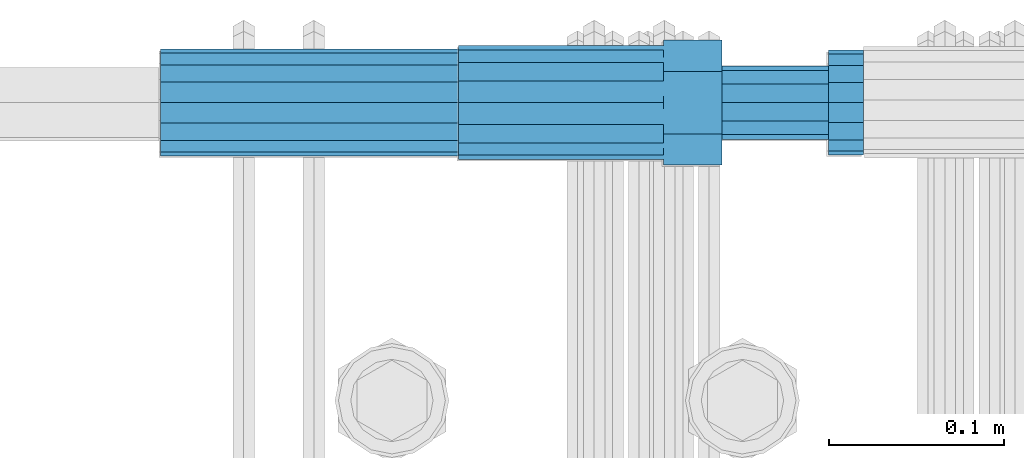
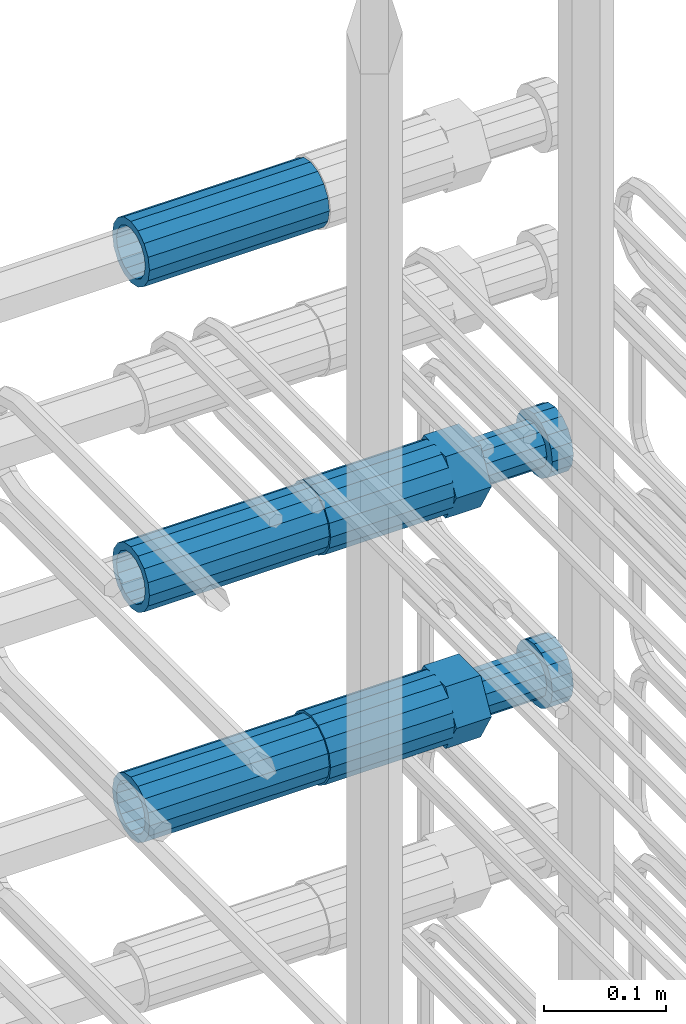
# One storey, part 55 of 177: 5 beams.
"""IFC2X3 building model written with IfcOpenShell, lengths in millimetres."""

from ifc_helpers import new_model, si_unit, frame, origin_with_axes, place, context, subcontext, project, spatial, faceted_brep, material, type_object, element, save


model = new_model("IFC2X3")

# Units and contexts
model_context_1 = context("Model", 3, precision=1e-05, world=origin_with_axes())
model_context_2 = context("Model", 3, precision=1e-05, world=origin_with_axes())
body_context = subcontext(model_context_2, "Body", "Model", "MODEL_VIEW")
ifc_project = project(units=[si_unit("LENGTHUNIT", "METRE", prefix="MILLI"), si_unit("AREAUNIT", "SQUARE_METRE"), si_unit("VOLUMEUNIT", "CUBIC_METRE"), si_unit("MASSUNIT", "GRAM", prefix="KILO"), si_unit("TIMEUNIT", "SECOND"), si_unit("PLANEANGLEUNIT", "RADIAN"), si_unit("SOLIDANGLEUNIT", "STERADIAN"), si_unit("THERMODYNAMICTEMPERATUREUNIT", "DEGREE_CELSIUS"), si_unit("LUMINOUSINTENSITYUNIT", "LUMEN")], contexts=[model_context_1])

# Site, building, storey
site_placement = place(None, origin_with_axes())
site = spatial("IfcSite", under=ifc_project, at=site_placement, CompositionType="ELEMENT")
building_placement = place(site_placement, origin_with_axes())
building = spatial("IfcBuilding", under=site, at=building_placement, Name="Undefined", CompositionType="ELEMENT")
storey_placement = place(building_placement, origin_with_axes())
storey = spatial("IfcBuildingStorey", under=building, at=storey_placement, Name="Undefined", CompositionType="ELEMENT", Elevation=0.0)

# Beams
ifc_material = material(Name="STEEL/S275")
beam_type_1 = type_object("IfcBeamType", PredefinedType="NOTDEFINED")
beam_1_placement = place(storey_placement, frame((2031449.01847313, 6206398.98588032, 21804.9868004311), z_axis=(0.0, 0.0, -1.0), x_axis=(1.0, 0.0, 0.0)))
element("IfcBeam", 1, at=beam_1_placement, inside=storey, type_object=beam_type_1, material=ifc_material, Name="AG40N", context=body_context, shape_type="Brep", body=[
    faceted_brep([(0.0, -23.5000000001164, -9.31322574615479e-10), (0.0, -21.7111690140155, 8.99306066054851), (170.0, -21.7111690140155, 8.99306066054851), (170.0, -23.5, 0.0), (0.0, -16.6170093578839, 16.6170093575493), (170.0, -16.6170093578839, 16.6170093575493), (0.0, -8.99306066057943, 21.7111690137535), (170.0, -8.99306066057943, 21.7111690137535), (0.0, 1.16415321826935e-10, 23.5), (170.0, 0.0, 23.5), (0.0, 8.99306066057943, 21.7111690137535), (170.0, 8.99306066057943, 21.7111690137535), (0.0, 16.6170093578839, 16.6170093575493), (170.0, 16.6170093578839, 16.6170093575493), (0.0, 21.7111690140155, 8.99306066054851), (170.0, 21.7111690140155, 8.99306066054851), (0.0, 23.5000000001164, -9.31322574615479e-10), (170.0, 23.5, 0.0), (0.0, 21.7111690140155, -8.99306066054851), (170.0, 21.7111690140155, -8.99306066054851), (0.0, 16.6170093578839, -16.6170093575493), (170.0, 16.6170093578839, -16.6170093575493), (0.0, 8.99306066057943, -21.7111690137535), (170.0, 8.99306066057943, -21.7111690137535), (0.0, 1.16415321826935e-10, -23.5000000009313), (170.0, 0.0, -23.5), (0.0, -8.99306066057943, -21.7111690137535), (170.0, -8.99306066057943, -21.7111690137535), (0.0, -16.6170093578839, -16.6170093575493), (170.0, -16.6170093578839, -16.6170093575493), (0.0, -21.7111690140155, -8.99306066054851), (170.0, -21.7111690140155, -8.99306066054851), (0.0, -30.5, 0.0), (0.0, -28.1783257415937, -11.6718446873128), (170.0, -28.1783257415937, -11.6718446873128), (170.0, -30.5, 0.0), (0.0, -21.5667568261888, -21.5667568258941), (170.0, -21.5667568261888, -21.5667568258941), (0.0, -11.6718446871346, -28.1783257415518), (170.0, -11.6718446871346, -28.1783257415518), (0.0, 0.0, -30.5), (170.0, 0.0, -30.5), (0.0, 11.6718446871346, -28.1783257415518), (170.0, 11.6718446871346, -28.1783257415518), (0.0, 21.5667568261888, -21.5667568258941), (170.0, 21.5667568261888, -21.5667568258941), (0.0, 28.1783257415937, -11.6718446873128), (170.0, 28.1783257415937, -11.6718446873128), (0.0, 30.5, 0.0), (170.0, 30.5, 0.0), (0.0, 28.1783257415937, 11.6718446873128), (170.0, 28.1783257415937, 11.6718446873128), (0.0, 21.5667568261888, 21.5667568258941), (170.0, 21.5667568261888, 21.5667568258941), (0.0, 11.6718446871346, 28.1783257415518), (170.0, 11.6718446871346, 28.1783257415518), (0.0, 0.0, 30.5), (170.0, 0.0, 30.5), (0.0, -11.6718446871346, 28.1783257415518), (170.0, -11.6718446871346, 28.1783257415518), (0.0, -21.5667568261888, 21.5667568258941), (170.0, -21.5667568261888, 21.5667568258941), (0.0, -28.1783257415937, 11.6718446873128), (170.0, -28.1783257415937, 11.6718446873128)], [[[0, 1, 2, 3]], [[1, 4, 5, 2]], [[4, 6, 7, 5]], [[6, 8, 9, 7]], [[8, 10, 11, 9]], [[10, 12, 13, 11]], [[12, 14, 15, 13]], [[14, 16, 17, 15]], [[16, 18, 19, 17]], [[18, 20, 21, 19]], [[20, 22, 23, 21]], [[22, 24, 25, 23]], [[24, 26, 27, 25]], [[26, 28, 29, 27]], [[28, 30, 31, 29]], [[30, 0, 3, 31]], [[32, 33, 34, 35]], [[33, 36, 37, 34]], [[36, 38, 39, 37]], [[38, 40, 41, 39]], [[40, 42, 43, 41]], [[42, 44, 45, 43]], [[44, 46, 47, 45]], [[46, 48, 49, 47]], [[48, 50, 51, 49]], [[50, 52, 53, 51]], [[52, 54, 55, 53]], [[54, 56, 57, 55]], [[56, 58, 59, 57]], [[58, 60, 61, 59]], [[60, 62, 63, 61]], [[62, 32, 35, 63]], [[37, 39, 41, 43, 45, 47, 49, 51, 53, 55, 57, 59, 61, 63, 35, 34], [5, 7, 9, 11, 13, 15, 17, 19, 21, 23, 25, 27, 29, 31, 3, 2]], [[62, 60, 58, 56, 54, 52, 50, 48, 46, 44, 42, 40, 38, 36, 33, 32], [30, 28, 26, 24, 22, 20, 18, 16, 14, 12, 10, 8, 6, 4, 1, 0]]]),
])
beam_2_placement = place(storey_placement, frame((2031449.01847313, 6206398.98588031, 22034.9868004306), z_axis=(0.0, 0.0, -1.0), x_axis=(1.0, 0.0, 0.0)))
element("IfcBeam", 2, at=beam_2_placement, inside=storey, type_object=beam_type_1, material=ifc_material, Name="AG40N", context=body_context, shape_type="Brep", body=[
    faceted_brep([(0.0, -23.5000000001164, -9.31322574615479e-10), (0.0, -21.7111690140155, 8.99306066054851), (170.0, -21.7111690140155, 8.99306066054851), (170.0, -23.5, 0.0), (0.0, -16.6170093578839, 16.6170093575493), (170.0, -16.6170093578839, 16.6170093575493), (0.0, -8.99306066057943, 21.7111690137535), (170.0, -8.99306066057943, 21.7111690137535), (0.0, 1.16415321826935e-10, 23.5), (170.0, 0.0, 23.5), (0.0, 8.99306066057943, 21.7111690137535), (170.0, 8.99306066057943, 21.7111690137535), (0.0, 16.6170093578839, 16.6170093575493), (170.0, 16.6170093578839, 16.6170093575493), (0.0, 21.7111690140155, 8.99306066054851), (170.0, 21.7111690140155, 8.99306066054851), (0.0, 23.5000000001164, -9.31322574615479e-10), (170.0, 23.5, 0.0), (0.0, 21.7111690140155, -8.99306066054851), (170.0, 21.7111690140155, -8.99306066054851), (0.0, 16.6170093578839, -16.6170093575493), (170.0, 16.6170093578839, -16.6170093575493), (0.0, 8.99306066057943, -21.7111690137535), (170.0, 8.99306066057943, -21.7111690137535), (0.0, 1.16415321826935e-10, -23.5000000009313), (170.0, 0.0, -23.5), (0.0, -8.99306066057943, -21.7111690137535), (170.0, -8.99306066057943, -21.7111690137535), (0.0, -16.6170093578839, -16.6170093575493), (170.0, -16.6170093578839, -16.6170093575493), (0.0, -21.7111690140155, -8.99306066054851), (170.0, -21.7111690140155, -8.99306066054851), (0.0, -30.5, 0.0), (0.0, -28.1783257415937, -11.6718446873128), (170.0, -28.1783257415937, -11.6718446873128), (170.0, -30.5, 0.0), (0.0, -21.5667568261888, -21.5667568258941), (170.0, -21.5667568261888, -21.5667568258941), (0.0, -11.6718446871346, -28.1783257415518), (170.0, -11.6718446871346, -28.1783257415518), (0.0, 0.0, -30.5), (170.0, 0.0, -30.5), (0.0, 11.6718446871346, -28.1783257415518), (170.0, 11.6718446871346, -28.1783257415518), (0.0, 21.5667568261888, -21.5667568258941), (170.0, 21.5667568261888, -21.5667568258941), (0.0, 28.1783257415937, -11.6718446873128), (170.0, 28.1783257415937, -11.6718446873128), (0.0, 30.5, 0.0), (170.0, 30.5, 0.0), (0.0, 28.1783257415937, 11.6718446873128), (170.0, 28.1783257415937, 11.6718446873128), (0.0, 21.5667568261888, 21.5667568258941), (170.0, 21.5667568261888, 21.5667568258941), (0.0, 11.6718446871346, 28.1783257415518), (170.0, 11.6718446871346, 28.1783257415518), (0.0, 0.0, 30.5), (170.0, 0.0, 30.5), (0.0, -11.6718446871346, 28.1783257415518), (170.0, -11.6718446871346, 28.1783257415518), (0.0, -21.5667568261888, 21.5667568258941), (170.0, -21.5667568261888, 21.5667568258941), (0.0, -28.1783257415937, 11.6718446873128), (170.0, -28.1783257415937, 11.6718446873128)], [[[0, 1, 2, 3]], [[1, 4, 5, 2]], [[4, 6, 7, 5]], [[6, 8, 9, 7]], [[8, 10, 11, 9]], [[10, 12, 13, 11]], [[12, 14, 15, 13]], [[14, 16, 17, 15]], [[16, 18, 19, 17]], [[18, 20, 21, 19]], [[20, 22, 23, 21]], [[22, 24, 25, 23]], [[24, 26, 27, 25]], [[26, 28, 29, 27]], [[28, 30, 31, 29]], [[30, 0, 3, 31]], [[32, 33, 34, 35]], [[33, 36, 37, 34]], [[36, 38, 39, 37]], [[38, 40, 41, 39]], [[40, 42, 43, 41]], [[42, 44, 45, 43]], [[44, 46, 47, 45]], [[46, 48, 49, 47]], [[48, 50, 51, 49]], [[50, 52, 53, 51]], [[52, 54, 55, 53]], [[54, 56, 57, 55]], [[56, 58, 59, 57]], [[58, 60, 61, 59]], [[60, 62, 63, 61]], [[62, 32, 35, 63]], [[37, 39, 41, 43, 45, 47, 49, 51, 53, 55, 57, 59, 61, 63, 35, 34], [5, 7, 9, 11, 13, 15, 17, 19, 21, 23, 25, 27, 29, 31, 3, 2]], [[62, 60, 58, 56, 54, 52, 50, 48, 46, 44, 42, 40, 38, 36, 33, 32], [30, 28, 26, 24, 22, 20, 18, 16, 14, 12, 10, 8, 6, 4, 1, 0]]]),
])
beam_3_placement = place(storey_placement, frame((2031449.01847313, 6206398.98588031, 22359.9868004311), z_axis=(0.0, 0.0, -1.0), x_axis=(1.0, 0.0, 0.0)))
element("IfcBeam", 3, at=beam_3_placement, inside=storey, type_object=beam_type_1, material=ifc_material, Name="AG40N", context=body_context, shape_type="Brep", body=[
    faceted_brep([(0.0, -23.5000000001164, -9.31322574615479e-10), (0.0, -21.7111690140155, 8.99306066054851), (170.0, -21.7111690140155, 8.99306066054851), (170.0, -23.5, 0.0), (0.0, -16.6170093578839, 16.6170093575493), (170.0, -16.6170093578839, 16.6170093575493), (0.0, -8.99306066057943, 21.7111690137535), (170.0, -8.99306066057943, 21.7111690137535), (0.0, 1.16415321826935e-10, 23.5), (170.0, 0.0, 23.5), (0.0, 8.99306066057943, 21.7111690137535), (170.0, 8.99306066057943, 21.7111690137535), (0.0, 16.6170093578839, 16.6170093575493), (170.0, 16.6170093578839, 16.6170093575493), (0.0, 21.7111690140155, 8.99306066054851), (170.0, 21.7111690140155, 8.99306066054851), (0.0, 23.5000000001164, -9.31322574615479e-10), (170.0, 23.5, 0.0), (0.0, 21.7111690140155, -8.99306066054851), (170.0, 21.7111690140155, -8.99306066054851), (0.0, 16.6170093578839, -16.6170093575493), (170.0, 16.6170093578839, -16.6170093575493), (0.0, 8.99306066057943, -21.7111690137535), (170.0, 8.99306066057943, -21.7111690137535), (0.0, 1.16415321826935e-10, -23.5000000009313), (170.0, 0.0, -23.5), (0.0, -8.99306066057943, -21.7111690137535), (170.0, -8.99306066057943, -21.7111690137535), (0.0, -16.6170093578839, -16.6170093575493), (170.0, -16.6170093578839, -16.6170093575493), (0.0, -21.7111690140155, -8.99306066054851), (170.0, -21.7111690140155, -8.99306066054851), (0.0, -30.5, 0.0), (0.0, -28.1783257415937, -11.6718446873128), (170.0, -28.1783257415937, -11.6718446873128), (170.0, -30.5, 0.0), (0.0, -21.5667568261888, -21.5667568258941), (170.0, -21.5667568261888, -21.5667568258941), (0.0, -11.6718446871346, -28.1783257415518), (170.0, -11.6718446871346, -28.1783257415518), (0.0, 0.0, -30.5), (170.0, 0.0, -30.5), (0.0, 11.6718446871346, -28.1783257415518), (170.0, 11.6718446871346, -28.1783257415518), (0.0, 21.5667568261888, -21.5667568258941), (170.0, 21.5667568261888, -21.5667568258941), (0.0, 28.1783257415937, -11.6718446873128), (170.0, 28.1783257415937, -11.6718446873128), (0.0, 30.5, 0.0), (170.0, 30.5, 0.0), (0.0, 28.1783257415937, 11.6718446873128), (170.0, 28.1783257415937, 11.6718446873128), (0.0, 21.5667568261888, 21.5667568258941), (170.0, 21.5667568261888, 21.5667568258941), (0.0, 11.6718446871346, 28.1783257415518), (170.0, 11.6718446871346, 28.1783257415518), (0.0, 0.0, 30.5), (170.0, 0.0, 30.5), (0.0, -11.6718446871346, 28.1783257415518), (170.0, -11.6718446871346, 28.1783257415518), (0.0, -21.5667568261888, 21.5667568258941), (170.0, -21.5667568261888, 21.5667568258941), (0.0, -28.1783257415937, 11.6718446873128), (170.0, -28.1783257415937, 11.6718446873128)], [[[0, 1, 2, 3]], [[1, 4, 5, 2]], [[4, 6, 7, 5]], [[6, 8, 9, 7]], [[8, 10, 11, 9]], [[10, 12, 13, 11]], [[12, 14, 15, 13]], [[14, 16, 17, 15]], [[16, 18, 19, 17]], [[18, 20, 21, 19]], [[20, 22, 23, 21]], [[22, 24, 25, 23]], [[24, 26, 27, 25]], [[26, 28, 29, 27]], [[28, 30, 31, 29]], [[30, 0, 3, 31]], [[32, 33, 34, 35]], [[33, 36, 37, 34]], [[36, 38, 39, 37]], [[38, 40, 41, 39]], [[40, 42, 43, 41]], [[42, 44, 45, 43]], [[44, 46, 47, 45]], [[46, 48, 49, 47]], [[48, 50, 51, 49]], [[50, 52, 53, 51]], [[52, 54, 55, 53]], [[54, 56, 57, 55]], [[56, 58, 59, 57]], [[58, 60, 61, 59]], [[60, 62, 63, 61]], [[62, 32, 35, 63]], [[37, 39, 41, 43, 45, 47, 49, 51, 53, 55, 57, 59, 61, 63, 35, 34], [5, 7, 9, 11, 13, 15, 17, 19, 21, 23, 25, 27, 29, 31, 3, 2]], [[62, 60, 58, 56, 54, 52, 50, 48, 46, 44, 42, 40, 38, 36, 33, 32], [30, 28, 26, 24, 22, 20, 18, 16, 14, 12, 10, 8, 6, 4, 1, 0]]]),
])
beam_type_2 = type_object("IfcBeamType", Name="ROD65", PredefinedType="NOTDEFINED")
beam_4_placement = place(storey_placement, frame((2031619.01847313, 6206398.98588032, 21804.9868004311), z_axis=(0.0, 0.0, -1.0), x_axis=(1.0, 0.0, 0.0)))
element("IfcBeam", 4, at=beam_4_placement, inside=storey, type_object=beam_type_2, material=ifc_material, Name="AGB40", ObjectType="ROD65", context=body_context, shape_type="Brep", body=[
    faceted_brep([(117.0, 8.17543110251427, 30.873805644922), (117.0, 17.8250000001863, 30.873805644922), (117.0, 22.0056958701462, 23.6326279877685), (117.0, 12.4372115517035, 30.0260848065373), (117.0, -17.8250000001863, 30.873805644922), (150.200000000186, -17.8250000001863, 30.873805644922), (150.200000000186, 17.8250000001863, 30.873805644922), (117.0, -8.17543110251427, 30.873805644922), (117.0, -12.4372115517035, 30.0260848065373), (117.0, -22.0056958701462, 23.6326279877685), (117.0, -35.6500000003725, 0.0), (150.200000000186, -35.6500000003725, 0.0), (117.0, -30.8443150008097, 8.32369058486074), (117.0, -32.5, 0.0), (117.0, -30.8443150008097, -8.32369058462791), (117.0, -17.8250000001863, -30.873805644922), (150.200000000186, -17.8250000001863, -30.873805644922), (117.0, -22.0056958701462, -23.6326279877685), (117.0, -12.4372115517035, -30.0260848065373), (117.0, -8.17543110251427, -30.873805644922), (117.0, 17.8250000001863, -30.873805644922), (150.200000000186, 17.8250000001863, -30.873805644922), (117.0, 8.17543110251427, -30.873805644922), (117.0, 22.0056958701462, -23.6326279877685), (117.0, 12.4372115517035, -30.0260848065373), (117.0, 35.6500000003725, 0.0), (150.200000000186, 35.6500000003725, 0.0), (117.0, 30.8443150008097, -8.32369058486074), (117.0, 30.8443150008097, 8.32369058462791), (117.0, 32.5, 0.0), (0.0, -22.9809703892097, 22.9809703885621), (0.0, -30.0260848058388, 12.4372115518636), (117.0, -30.0260848067701, 12.4372115519363), (117.0, -22.9809703882784, 22.9809703885112), (-2.3283064365387e-10, 22.9809703892097, -22.9809703885639), (-4.65661287307739e-10, 30.0260848077014, -12.4372115518672), (117.0, 30.0260848067701, -12.4372115519363), (117.0, 22.9809703882784, -22.9809703885112), (-2.3283064365387e-10, -30.0260848067701, -12.4372115518672), (-2.3283064365387e-10, -22.9809703892097, -22.9809703885621), (117.0, -22.9809703882784, -22.9809703885112), (117.0, -30.0260848067701, -12.4372115519363), (-2.3283064365387e-10, -12.4372115507722, 30.0260848066137), (-2.3283064365387e-10, 9.31322574615479e-10, 32.4999999999982), (-2.3283064365387e-10, 12.4372115526348, 30.0260848066137), (0.0, 22.9809703892097, 22.9809703885621), (-2.3283064365387e-10, 30.0260848077014, 12.4372115518636), (-2.3283064365387e-10, 32.5, 0.0), (-2.3283064365387e-10, 12.4372115526348, -30.0260848066173), (-2.3283064365387e-10, 9.31322574615479e-10, -32.5), (-2.3283064365387e-10, -12.4372115517035, -30.0260848066173), (-4.65661287307739e-10, -32.4999999990687, -1.81898940354586e-12), (117.0, 22.9809703882784, 22.9809703885112), (117.0, 30.0260848067701, 12.4372115519363), (117.0, 0.0, -32.5), (117.0, 0.0, 32.5), (150.200000000186, 10.5, -18.1865334794857), (150.200000000186, 0.0, -21.0), (150.200000000186, -10.5, -18.1865334794857), (150.200000000186, -18.18653347902, -10.5), (150.200000000186, -21.0, 0.0), (150.200000000186, -18.18653347902, 10.5), (150.200000000186, -10.5, 18.1865334794857), (150.200000000186, 0.0, 21.0), (150.200000000186, 10.5, 18.1865334794857), (150.200000000186, 18.18653347902, 10.5), (150.200000000186, 21.0, 0.0), (150.200000000186, 18.18653347902, -10.5), (210.980000000447, -18.18653347902, 10.5), (210.980000000447, -21.0, 0.0), (210.980000000447, -10.5, 18.1865334794857), (210.980000000447, 0.0, 21.0), (210.980000000447, 10.5, 18.1865334794857), (210.980000000447, 18.18653347902, 10.5), (210.980000000447, 21.0, 0.0), (210.980000000447, 18.18653347902, -10.5), (210.980000000447, 10.5, -18.1865334794857), (210.980000000447, 0.0, -21.0), (210.980000000447, -10.5, -18.1865334794857), (210.980000000447, -18.18653347902, -10.5), (211.001368442696, -27.7269937992096, -11.491116326768), (211.003082550167, -21.2238094303757, -21.223815418547), (231.002518367059, -21.2131944671273, -21.2132004550658), (231.000804259587, -27.7163788359612, -11.4805013632867), (211.001368440451, -11.4911085031927, -27.7269970395137), (231.000804257343, -11.4804935399443, -27.7163820760325), (210.996487071217, -0.0106065049767494, -30.0106107392348), (230.995922888109, 8.45827162265778e-06, -29.9999957757536), (210.989181586672, 11.46989420522, -27.7269970329944), (230.988617403564, 11.4805091684684, -27.7163820695132), (210.980564180623, 21.2025914648548, -21.2238154064398), (230.979999997515, 21.2132064281031, -21.2132004429586), (210.971946775022, 27.7057703435421, -11.4911163107026), (230.971382591913, 27.7163853067905, -11.4805013472214), (210.96464129175, 29.9893808094785, -0.0106149562634528), (230.964077108642, 29.9999957727268, 7.21774995326996e-09), (210.959759924415, 27.7057638689876, 11.4698863970116), (230.959195741307, 27.7163788322359, 11.4805013604928), (210.958045816944, 21.2025795001537, 21.2025854887906), (230.957481633835, 21.213194463402, 21.2132004522718), (210.95975992666, 11.4698785729706, 27.7057671097573), (230.959195743551, 11.480493536219, 27.7163820732385), (210.964641295894, -0.010623425245285, 29.9893808094785), (230.964077112785, -8.46199691295624e-06, 29.9999957729597), (210.971946780439, -11.4911241354421, 27.705767103238), (230.97138259733, -11.4805091721937, 27.7163820667192), (210.980564186488, -21.2238213950768, 21.2025854766835), (230.980000003379, -21.2132064318284, 21.2132004401647), (210.989181592089, -27.7270002737641, 11.4698863809463), (230.988617408981, -27.7163853105158, 11.4805013444275), (210.996487075361, -30.0106107397005, -0.0106149734929204), (230.995922892253, -29.9999957764521, -1.00117176771164e-08)], [[[0, 1, 2, 3]], [[4, 5, 6, 1, 0, 7]], [[4, 7, 8, 9]], [[10, 11, 5, 4, 9, 12]], [[10, 12, 13, 14]], [[15, 16, 11, 10, 14, 17]], [[15, 17, 18, 19]], [[20, 21, 16, 15, 19, 22]], [[23, 20, 22, 24]], [[25, 26, 21, 20, 23, 27]], [[28, 25, 27, 29]], [[30, 31, 32, 33]], [[34, 35, 36, 37]], [[38, 39, 40, 41]], [[31, 30, 42, 43, 44, 45, 46, 47, 35, 34, 48, 49, 50, 39, 38, 51]], [[46, 45, 52, 53]], [[29, 47, 46, 53, 28]], [[27, 36, 35, 47, 29]], [[23, 37, 36, 27]], [[24, 48, 34, 37, 23]], [[22, 54, 49, 48, 24]], [[19, 54, 22]], [[18, 50, 49, 54, 19]], [[17, 40, 39, 50, 18]], [[14, 41, 40, 17]], [[13, 51, 38, 41, 14]], [[12, 32, 31, 51, 13]], [[9, 33, 32, 12]], [[8, 42, 30, 33, 9]], [[7, 55, 43, 42, 8]], [[0, 55, 7]], [[3, 44, 43, 55, 0]], [[2, 52, 45, 44, 3]], [[28, 53, 52, 2]], [[1, 6, 26, 25, 28, 2]], [[5, 11, 16, 21, 26, 6], [56, 57, 58, 59, 60, 61, 62, 63, 64, 65, 66, 67]], [[68, 61, 60, 69]], [[70, 62, 61, 68]], [[71, 63, 62, 70]], [[72, 64, 63, 71]], [[73, 65, 64, 72]], [[74, 66, 65, 73]], [[75, 67, 66, 74]], [[76, 56, 67, 75]], [[77, 57, 56, 76]], [[78, 58, 57, 77]], [[79, 59, 58, 78]], [[69, 60, 59, 79]], [[80, 81, 82, 83]], [[81, 84, 85, 82]], [[84, 86, 87, 85]], [[86, 88, 89, 87]], [[88, 90, 91, 89]], [[90, 92, 93, 91]], [[92, 94, 95, 93]], [[94, 96, 97, 95]], [[96, 98, 99, 97]], [[98, 100, 101, 99]], [[100, 102, 103, 101]], [[102, 104, 105, 103]], [[104, 106, 107, 105]], [[106, 108, 109, 107]], [[108, 110, 111, 109]], [[82, 85, 87, 89, 91, 93, 95, 97, 99, 101, 103, 105, 107, 109, 111, 83]], [[110, 80, 83, 111]], [[108, 106, 104, 102, 100, 98, 96, 94, 92, 90, 88, 86, 84, 81, 80, 110], [75, 74, 73, 72, 71, 70, 68, 69, 79, 78, 77, 76]]]),
])
beam_5_placement = place(storey_placement, frame((2031619.01847313, 6206398.98588031, 22034.9868004306), z_axis=(0.0, 0.0, -1.0), x_axis=(1.0, 0.0, 0.0)))
element("IfcBeam", 5, at=beam_5_placement, inside=storey, type_object=beam_type_2, material=ifc_material, Name="AGB40", ObjectType="ROD65", context=body_context, shape_type="Brep", body=[
    faceted_brep([(117.0, 8.17543110251427, 30.873805644922), (117.0, 17.8250000001863, 30.873805644922), (117.0, 22.0056958701462, 23.6326279877685), (117.0, 12.4372115517035, 30.0260848065373), (117.0, -17.8250000001863, 30.873805644922), (150.200000000186, -17.8250000001863, 30.873805644922), (150.200000000186, 17.8250000001863, 30.873805644922), (117.0, -8.17543110251427, 30.873805644922), (117.0, -12.4372115517035, 30.0260848065373), (117.0, -22.0056958701462, 23.6326279877685), (117.0, -35.6500000003725, 0.0), (150.200000000186, -35.6500000003725, 0.0), (117.0, -30.8443150008097, 8.32369058486074), (117.0, -32.5, 0.0), (117.0, -30.8443150008097, -8.32369058462791), (117.0, -17.8250000001863, -30.873805644922), (150.200000000186, -17.8250000001863, -30.873805644922), (117.0, -22.0056958701462, -23.6326279877685), (117.0, -12.4372115517035, -30.0260848065373), (117.0, -8.17543110251427, -30.873805644922), (117.0, 17.8250000001863, -30.873805644922), (150.200000000186, 17.8250000001863, -30.873805644922), (117.0, 8.17543110251427, -30.873805644922), (117.0, 22.0056958701462, -23.6326279877685), (117.0, 12.4372115517035, -30.0260848065373), (117.0, 35.6500000003725, 0.0), (150.200000000186, 35.6500000003725, 0.0), (117.0, 30.8443150008097, -8.32369058486074), (117.0, 30.8443150008097, 8.32369058462791), (117.0, 32.5, 0.0), (0.0, -22.9809703892097, 22.9809703885621), (0.0, -30.0260848058388, 12.4372115518636), (117.0, -30.0260848067701, 12.4372115519363), (117.0, -22.9809703882784, 22.9809703885112), (-2.3283064365387e-10, 22.9809703892097, -22.9809703885639), (-4.65661287307739e-10, 30.0260848077014, -12.4372115518672), (117.0, 30.0260848067701, -12.4372115519363), (117.0, 22.9809703882784, -22.9809703885112), (-2.3283064365387e-10, -30.0260848067701, -12.4372115518672), (-2.3283064365387e-10, -22.9809703892097, -22.9809703885621), (117.0, -22.9809703882784, -22.9809703885112), (117.0, -30.0260848067701, -12.4372115519363), (-2.3283064365387e-10, -12.4372115507722, 30.0260848066137), (-2.3283064365387e-10, 9.31322574615479e-10, 32.4999999999982), (-2.3283064365387e-10, 12.4372115526348, 30.0260848066137), (0.0, 22.9809703892097, 22.9809703885621), (-2.3283064365387e-10, 30.0260848077014, 12.4372115518636), (-2.3283064365387e-10, 32.5, 0.0), (-2.3283064365387e-10, 12.4372115526348, -30.0260848066173), (-2.3283064365387e-10, 9.31322574615479e-10, -32.5), (-2.3283064365387e-10, -12.4372115517035, -30.0260848066173), (-4.65661287307739e-10, -32.4999999990687, -1.81898940354586e-12), (117.0, 22.9809703882784, 22.9809703885112), (117.0, 30.0260848067701, 12.4372115519363), (117.0, 0.0, -32.5), (117.0, 0.0, 32.5), (150.200000000186, 10.5, -18.1865334794857), (150.200000000186, 0.0, -21.0), (150.200000000186, -10.5, -18.1865334794857), (150.200000000186, -18.18653347902, -10.5), (150.200000000186, -21.0, 0.0), (150.200000000186, -18.18653347902, 10.5), (150.200000000186, -10.5, 18.1865334794857), (150.200000000186, 0.0, 21.0), (150.200000000186, 10.5, 18.1865334794857), (150.200000000186, 18.18653347902, 10.5), (150.200000000186, 21.0, 0.0), (150.200000000186, 18.18653347902, -10.5), (210.980000000447, -18.18653347902, 10.5), (210.980000000447, -21.0, 0.0), (210.980000000447, -10.5, 18.1865334794857), (210.980000000447, 0.0, 21.0), (210.980000000447, 10.5, 18.1865334794857), (210.980000000447, 18.18653347902, 10.5), (210.980000000447, 21.0, 0.0), (210.980000000447, 18.18653347902, -10.5), (210.980000000447, 10.5, -18.1865334794857), (210.980000000447, 0.0, -21.0), (210.980000000447, -10.5, -18.1865334794857), (210.980000000447, -18.18653347902, -10.5), (211.001368442696, -27.7269937992096, -11.491116326768), (211.003082550167, -21.2238094303757, -21.223815418547), (231.002518367059, -21.2131944671273, -21.2132004550658), (231.000804259587, -27.7163788359612, -11.4805013632867), (211.001368440451, -11.4911085031927, -27.7269970395137), (231.000804257343, -11.4804935399443, -27.7163820760325), (210.996487071217, -0.0106065049767494, -30.0106107392348), (230.995922888109, 8.45827162265778e-06, -29.9999957757536), (210.989181586672, 11.46989420522, -27.7269970329944), (230.988617403564, 11.4805091684684, -27.7163820695132), (210.980564180623, 21.2025914648548, -21.2238154064398), (230.979999997515, 21.2132064281031, -21.2132004429586), (210.971946775022, 27.7057703435421, -11.4911163107026), (230.971382591913, 27.7163853067905, -11.4805013472214), (210.96464129175, 29.9893808094785, -0.0106149562634528), (230.964077108642, 29.9999957727268, 7.21774995326996e-09), (210.959759924415, 27.7057638689876, 11.4698863970116), (230.959195741307, 27.7163788322359, 11.4805013604928), (210.958045816944, 21.2025795001537, 21.2025854887906), (230.957481633835, 21.213194463402, 21.2132004522718), (210.95975992666, 11.4698785729706, 27.7057671097573), (230.959195743551, 11.480493536219, 27.7163820732385), (210.964641295894, -0.010623425245285, 29.9893808094785), (230.964077112785, -8.46199691295624e-06, 29.9999957729597), (210.971946780439, -11.4911241354421, 27.705767103238), (230.97138259733, -11.4805091721937, 27.7163820667192), (210.980564186488, -21.2238213950768, 21.2025854766835), (230.980000003379, -21.2132064318284, 21.2132004401647), (210.989181592089, -27.7270002737641, 11.4698863809463), (230.988617408981, -27.7163853105158, 11.4805013444275), (210.996487075361, -30.0106107397005, -0.0106149734929204), (230.995922892253, -29.9999957764521, -1.00117176771164e-08)], [[[0, 1, 2, 3]], [[4, 5, 6, 1, 0, 7]], [[4, 7, 8, 9]], [[10, 11, 5, 4, 9, 12]], [[10, 12, 13, 14]], [[15, 16, 11, 10, 14, 17]], [[15, 17, 18, 19]], [[20, 21, 16, 15, 19, 22]], [[23, 20, 22, 24]], [[25, 26, 21, 20, 23, 27]], [[28, 25, 27, 29]], [[30, 31, 32, 33]], [[34, 35, 36, 37]], [[38, 39, 40, 41]], [[31, 30, 42, 43, 44, 45, 46, 47, 35, 34, 48, 49, 50, 39, 38, 51]], [[46, 45, 52, 53]], [[29, 47, 46, 53, 28]], [[27, 36, 35, 47, 29]], [[23, 37, 36, 27]], [[24, 48, 34, 37, 23]], [[22, 54, 49, 48, 24]], [[19, 54, 22]], [[18, 50, 49, 54, 19]], [[17, 40, 39, 50, 18]], [[14, 41, 40, 17]], [[13, 51, 38, 41, 14]], [[12, 32, 31, 51, 13]], [[9, 33, 32, 12]], [[8, 42, 30, 33, 9]], [[7, 55, 43, 42, 8]], [[0, 55, 7]], [[3, 44, 43, 55, 0]], [[2, 52, 45, 44, 3]], [[28, 53, 52, 2]], [[1, 6, 26, 25, 28, 2]], [[5, 11, 16, 21, 26, 6], [56, 57, 58, 59, 60, 61, 62, 63, 64, 65, 66, 67]], [[68, 61, 60, 69]], [[70, 62, 61, 68]], [[71, 63, 62, 70]], [[72, 64, 63, 71]], [[73, 65, 64, 72]], [[74, 66, 65, 73]], [[75, 67, 66, 74]], [[76, 56, 67, 75]], [[77, 57, 56, 76]], [[78, 58, 57, 77]], [[79, 59, 58, 78]], [[69, 60, 59, 79]], [[80, 81, 82, 83]], [[81, 84, 85, 82]], [[84, 86, 87, 85]], [[86, 88, 89, 87]], [[88, 90, 91, 89]], [[90, 92, 93, 91]], [[92, 94, 95, 93]], [[94, 96, 97, 95]], [[96, 98, 99, 97]], [[98, 100, 101, 99]], [[100, 102, 103, 101]], [[102, 104, 105, 103]], [[104, 106, 107, 105]], [[106, 108, 109, 107]], [[108, 110, 111, 109]], [[82, 85, 87, 89, 91, 93, 95, 97, 99, 101, 103, 105, 107, 109, 111, 83]], [[110, 80, 83, 111]], [[108, 106, 104, 102, 100, 98, 96, 94, 92, 90, 88, 86, 84, 81, 80, 110], [75, 74, 73, 72, 71, 70, 68, 69, 79, 78, 77, 76]]]),
])

save(model, "model.ifc")
